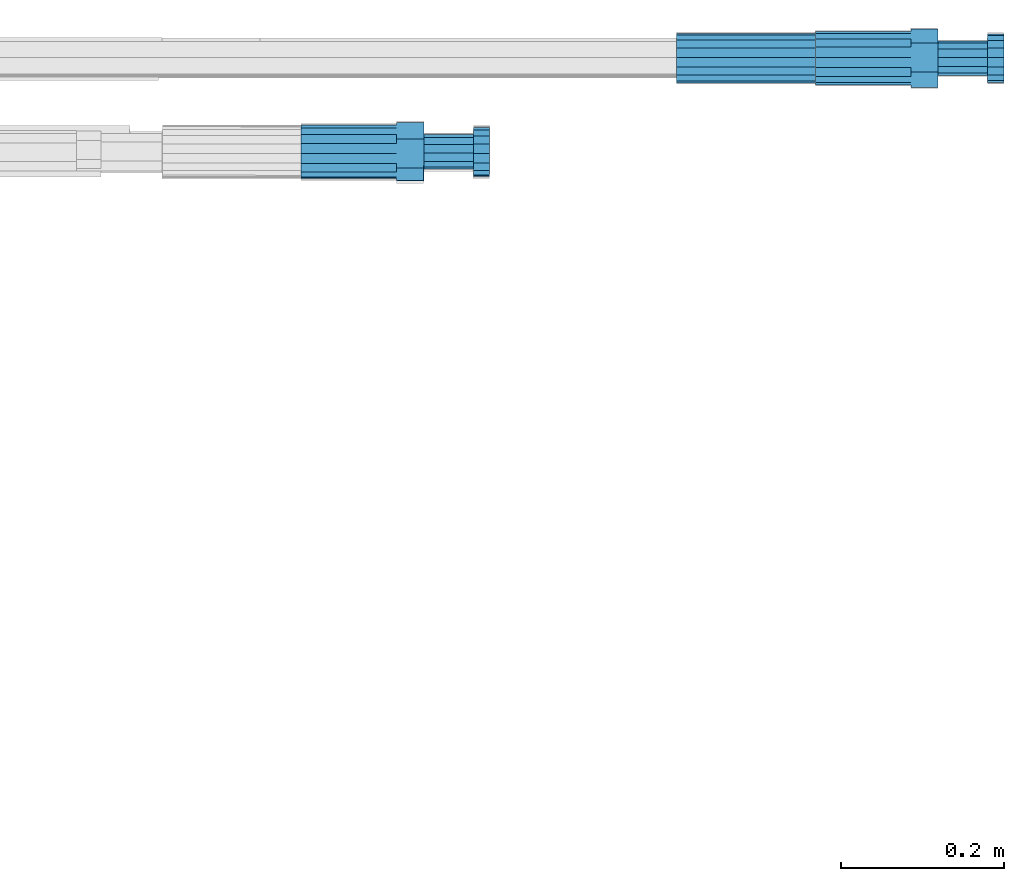
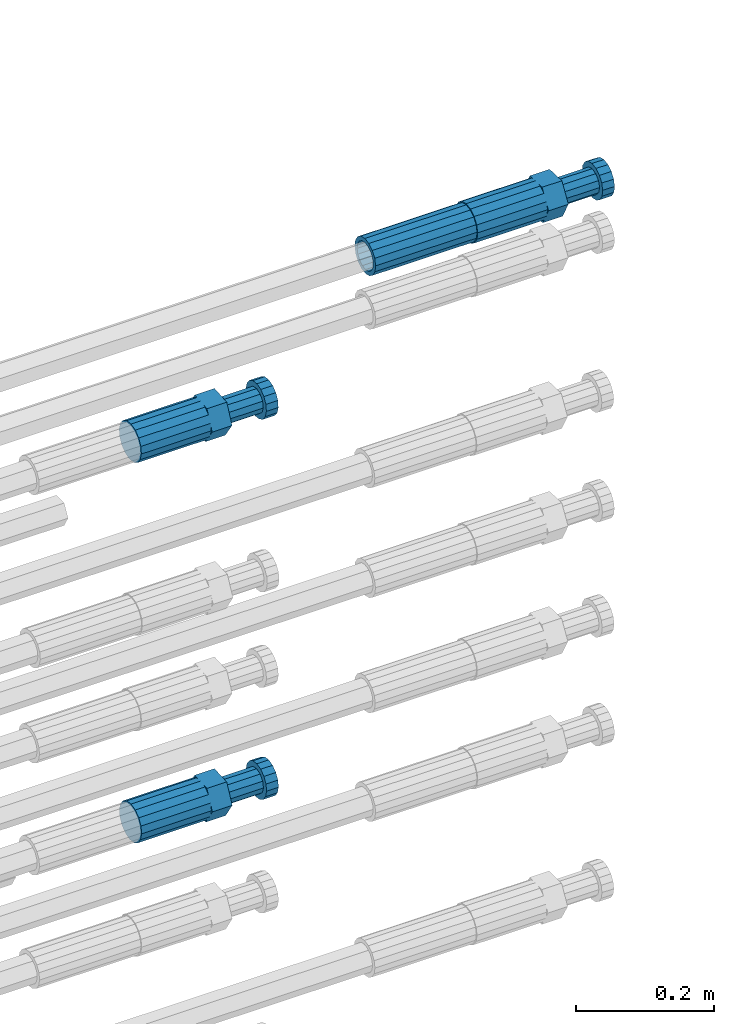
# One storey, part 111 of 177: 4 beams.
"""IFC2X3 building model written with IfcOpenShell, lengths in millimetres."""

from ifc_helpers import new_model, si_unit, frame, origin_with_axes, place, context, subcontext, project, spatial, faceted_brep, material, type_object, element, save


model = new_model("IFC2X3")

# Units and contexts
model_context_1 = context("Model", 3, precision=1e-05, world=origin_with_axes())
model_context_2 = context("Model", 3, precision=1e-05, world=origin_with_axes())
body_context = subcontext(model_context_2, "Body", "Model", "MODEL_VIEW")
ifc_project = project(units=[si_unit("LENGTHUNIT", "METRE", prefix="MILLI"), si_unit("AREAUNIT", "SQUARE_METRE"), si_unit("VOLUMEUNIT", "CUBIC_METRE"), si_unit("MASSUNIT", "GRAM", prefix="KILO"), si_unit("TIMEUNIT", "SECOND"), si_unit("PLANEANGLEUNIT", "RADIAN"), si_unit("SOLIDANGLEUNIT", "STERADIAN"), si_unit("THERMODYNAMICTEMPERATUREUNIT", "DEGREE_CELSIUS"), si_unit("LUMINOUSINTENSITYUNIT", "LUMEN")], contexts=[model_context_1])

# Site, building, storey
site_placement = place(None, origin_with_axes())
site = spatial("IfcSite", under=ifc_project, at=site_placement, CompositionType="ELEMENT")
building_placement = place(site_placement, origin_with_axes())
building = spatial("IfcBuilding", under=site, at=building_placement, Name="Undefined", CompositionType="ELEMENT")
storey_placement = place(building_placement, origin_with_axes())
storey = spatial("IfcBuildingStorey", under=building, at=storey_placement, Name="Undefined", CompositionType="ELEMENT", Elevation=0.0)

# Beams
ifc_material = material(Name="STEEL/S275")
beam_type_1 = type_object("IfcBeamType", PredefinedType="NOTDEFINED")
beam_1_placement = place(storey_placement, frame((2039349.51584447, 6206399.26006595, 20839.4518890081), z_axis=(0.0, -0.0348994960021223, -0.999390827043554), x_axis=(1.0, 0.0, 0.0)))
element("IfcBeam", 1, at=beam_1_placement, inside=storey, type_object=beam_type_1, material=ifc_material, Name="AG40N", context=body_context, shape_type="Brep", body=[
    faceted_brep([(0.0, -23.5000000001164, -9.31322574615479e-10), (0.0, -21.7111690140155, 8.99306066054851), (170.0, -21.7111690140155, 8.99306066054851), (170.0, -23.5, 0.0), (0.0, -16.6170093578839, 16.6170093575493), (170.0, -16.6170093578839, 16.6170093575493), (0.0, -8.99306066057943, 21.7111690137535), (170.0, -8.99306066057943, 21.7111690137535), (0.0, 1.16415321826935e-10, 23.5), (170.0, 0.0, 23.5), (0.0, 8.99306066057943, 21.7111690137535), (170.0, 8.99306066057943, 21.7111690137535), (0.0, 16.6170093578839, 16.6170093575493), (170.0, 16.6170093578839, 16.6170093575493), (0.0, 21.7111690140155, 8.99306066054851), (170.0, 21.7111690140155, 8.99306066054851), (0.0, 23.5000000001164, -9.31322574615479e-10), (170.0, 23.5, 0.0), (0.0, 21.7111690140155, -8.99306066054851), (170.0, 21.7111690140155, -8.99306066054851), (0.0, 16.6170093578839, -16.6170093575493), (170.0, 16.6170093578839, -16.6170093575493), (0.0, 8.99306066057943, -21.7111690137535), (170.0, 8.99306066057943, -21.7111690137535), (0.0, 1.16415321826935e-10, -23.5000000009313), (170.0, 0.0, -23.5), (0.0, -8.99306066057943, -21.7111690137535), (170.0, -8.99306066057943, -21.7111690137535), (0.0, -16.6170093578839, -16.6170093575493), (170.0, -16.6170093578839, -16.6170093575493), (0.0, -21.7111690140155, -8.99306066054851), (170.0, -21.7111690140155, -8.99306066054851), (0.0, -30.5, 0.0), (0.0, -28.1783257415937, -11.6718446873128), (170.0, -28.1783257415937, -11.6718446873128), (170.0, -30.5, 0.0), (0.0, -21.5667568261888, -21.5667568258941), (170.0, -21.5667568261888, -21.5667568258941), (0.0, -11.6718446871346, -28.1783257415518), (170.0, -11.6718446871346, -28.1783257415518), (0.0, 0.0, -30.5), (170.0, 0.0, -30.5), (0.0, 11.6718446871346, -28.1783257415518), (170.0, 11.6718446871346, -28.1783257415518), (0.0, 21.5667568261888, -21.5667568258941), (170.0, 21.5667568261888, -21.5667568258941), (0.0, 28.1783257415937, -11.6718446873128), (170.0, 28.1783257415937, -11.6718446873128), (0.0, 30.5, 0.0), (170.0, 30.5, 0.0), (0.0, 28.1783257415937, 11.6718446873128), (170.0, 28.1783257415937, 11.6718446873128), (0.0, 21.5667568261888, 21.5667568258941), (170.0, 21.5667568261888, 21.5667568258941), (0.0, 11.6718446871346, 28.1783257415518), (170.0, 11.6718446871346, 28.1783257415518), (0.0, 0.0, 30.5), (170.0, 0.0, 30.5), (0.0, -11.6718446871346, 28.1783257415518), (170.0, -11.6718446871346, 28.1783257415518), (0.0, -21.5667568261888, 21.5667568258941), (170.0, -21.5667568261888, 21.5667568258941), (0.0, -28.1783257415937, 11.6718446873128), (170.0, -28.1783257415937, 11.6718446873128)], [[[0, 1, 2, 3]], [[1, 4, 5, 2]], [[4, 6, 7, 5]], [[6, 8, 9, 7]], [[8, 10, 11, 9]], [[10, 12, 13, 11]], [[12, 14, 15, 13]], [[14, 16, 17, 15]], [[16, 18, 19, 17]], [[18, 20, 21, 19]], [[20, 22, 23, 21]], [[22, 24, 25, 23]], [[24, 26, 27, 25]], [[26, 28, 29, 27]], [[28, 30, 31, 29]], [[30, 0, 3, 31]], [[32, 33, 34, 35]], [[33, 36, 37, 34]], [[36, 38, 39, 37]], [[38, 40, 41, 39]], [[40, 42, 43, 41]], [[42, 44, 45, 43]], [[44, 46, 47, 45]], [[46, 48, 49, 47]], [[48, 50, 51, 49]], [[50, 52, 53, 51]], [[52, 54, 55, 53]], [[54, 56, 57, 55]], [[56, 58, 59, 57]], [[58, 60, 61, 59]], [[60, 62, 63, 61]], [[62, 32, 35, 63]], [[37, 39, 41, 43, 45, 47, 49, 51, 53, 55, 57, 59, 61, 63, 35, 34], [5, 7, 9, 11, 13, 15, 17, 19, 21, 23, 25, 27, 29, 31, 3, 2]], [[62, 60, 58, 56, 54, 52, 50, 48, 46, 44, 42, 40, 38, 36, 33, 32], [30, 28, 26, 24, 22, 20, 18, 16, 14, 12, 10, 8, 6, 4, 1, 0]]]),
])
beam_type_2 = type_object("IfcBeamType", Name="ROD65", PredefinedType="NOTDEFINED")
beam_2_placement = place(storey_placement, frame((2039519.51584447, 6206399.26006595, 20839.4518890082), z_axis=(0.0, -0.0348994960021223, -0.999390827043554), x_axis=(1.0, 0.0, 0.0)))
element("IfcBeam", 2, at=beam_2_placement, inside=storey, type_object=beam_type_2, material=ifc_material, Name="AGB40", ObjectType="ROD65", context=body_context, shape_type="Brep", body=[
    faceted_brep([(117.0, 8.17543110251427, 30.873805644922), (117.0, 17.8250000001863, 30.873805644922), (117.0, 22.0056958701462, 23.6326279877685), (117.0, 12.4372115517035, 30.0260848065373), (117.0, -17.8250000001863, 30.873805644922), (150.200000000186, -17.8250000001863, 30.873805644922), (150.200000000186, 17.8250000001863, 30.873805644922), (117.0, -8.17543110251427, 30.873805644922), (117.0, -12.4372115517035, 30.0260848065373), (117.0, -22.0056958701462, 23.6326279877685), (117.0, -35.6500000003725, 0.0), (150.200000000186, -35.6500000003725, 0.0), (117.0, -30.8443150008097, 8.32369058486074), (117.0, -32.5, 0.0), (117.0, -30.8443150008097, -8.32369058462791), (117.0, -17.8250000001863, -30.873805644922), (150.200000000186, -17.8250000001863, -30.873805644922), (117.0, -22.0056958701462, -23.6326279877685), (117.0, -12.4372115517035, -30.0260848065373), (117.0, -8.17543110251427, -30.873805644922), (117.0, 17.8250000001863, -30.873805644922), (150.200000000186, 17.8250000001863, -30.873805644922), (117.0, 8.17543110251427, -30.873805644922), (117.0, 22.0056958701462, -23.6326279877685), (117.0, 12.4372115517035, -30.0260848065373), (117.0, 35.6500000003725, 0.0), (150.200000000186, 35.6500000003725, 0.0), (117.0, 30.8443150008097, -8.32369058486074), (117.0, 30.8443150008097, 8.32369058462791), (117.0, 32.5, 0.0), (0.0, -22.9809703892097, 22.9809703885621), (0.0, -30.0260848058388, 12.4372115518636), (117.0, -30.0260848067701, 12.4372115519363), (117.0, -22.9809703882784, 22.9809703885112), (-2.3283064365387e-10, 22.9809703892097, -22.9809703885639), (-4.65661287307739e-10, 30.0260848077014, -12.4372115518672), (117.0, 30.0260848067701, -12.4372115519363), (117.0, 22.9809703882784, -22.9809703885112), (-2.3283064365387e-10, -30.0260848067701, -12.4372115518672), (-2.3283064365387e-10, -22.9809703892097, -22.9809703885621), (117.0, -22.9809703882784, -22.9809703885112), (117.0, -30.0260848067701, -12.4372115519363), (-2.3283064365387e-10, -12.4372115507722, 30.0260848066137), (-2.3283064365387e-10, 9.31322574615479e-10, 32.4999999999982), (-2.3283064365387e-10, 12.4372115526348, 30.0260848066137), (0.0, 22.9809703892097, 22.9809703885621), (-2.3283064365387e-10, 30.0260848077014, 12.4372115518636), (-2.3283064365387e-10, 32.5, 0.0), (-2.3283064365387e-10, 12.4372115526348, -30.0260848066173), (-2.3283064365387e-10, 9.31322574615479e-10, -32.5), (-2.3283064365387e-10, -12.4372115517035, -30.0260848066173), (-4.65661287307739e-10, -32.4999999990687, -1.81898940354586e-12), (117.0, 22.9809703882784, 22.9809703885112), (117.0, 30.0260848067701, 12.4372115519363), (117.0, 0.0, -32.5), (117.0, 0.0, 32.5), (150.200000000186, 10.5, -18.1865334794857), (150.200000000186, 0.0, -21.0), (150.200000000186, -10.5, -18.1865334794857), (150.200000000186, -18.18653347902, -10.5), (150.200000000186, -21.0, 0.0), (150.200000000186, -18.18653347902, 10.5), (150.200000000186, -10.5, 18.1865334794857), (150.200000000186, 0.0, 21.0), (150.200000000186, 10.5, 18.1865334794857), (150.200000000186, 18.18653347902, 10.5), (150.200000000186, 21.0, 0.0), (150.200000000186, 18.18653347902, -10.5), (210.980000000447, -18.18653347902, 10.5), (210.980000000447, -21.0, 0.0), (210.980000000447, -10.5, 18.1865334794857), (210.980000000447, 0.0, 21.0), (210.980000000447, 10.5, 18.1865334794857), (210.980000000447, 18.18653347902, 10.5), (210.980000000447, 21.0, 0.0), (210.980000000447, 18.18653347902, -10.5), (210.980000000447, 10.5, -18.1865334794857), (210.980000000447, 0.0, -21.0), (210.980000000447, -10.5, -18.1865334794857), (210.980000000447, -18.18653347902, -10.5), (211.001368442696, -27.7269937992096, -11.491116326768), (211.003082550167, -21.2238094303757, -21.223815418547), (231.002518367059, -21.2131944671273, -21.2132004550658), (231.000804259587, -27.7163788359612, -11.4805013632867), (211.001368440451, -11.4911085031927, -27.7269970395137), (231.000804257343, -11.4804935399443, -27.7163820760325), (210.996487071217, -0.0106065049767494, -30.0106107392348), (230.995922888109, 8.45827162265778e-06, -29.9999957757536), (210.989181586672, 11.46989420522, -27.7269970329944), (230.988617403564, 11.4805091684684, -27.7163820695132), (210.980564180623, 21.2025914648548, -21.2238154064398), (230.979999997515, 21.2132064281031, -21.2132004429586), (210.971946775022, 27.7057703435421, -11.4911163107026), (230.971382591913, 27.7163853067905, -11.4805013472214), (210.96464129175, 29.9893808094785, -0.0106149562634528), (230.964077108642, 29.9999957727268, 7.21774995326996e-09), (210.959759924415, 27.7057638689876, 11.4698863970116), (230.959195741307, 27.7163788322359, 11.4805013604928), (210.958045816944, 21.2025795001537, 21.2025854887906), (230.957481633835, 21.213194463402, 21.2132004522718), (210.95975992666, 11.4698785729706, 27.7057671097573), (230.959195743551, 11.480493536219, 27.7163820732385), (210.964641295894, -0.010623425245285, 29.9893808094785), (230.964077112785, -8.46199691295624e-06, 29.9999957729597), (210.971946780439, -11.4911241354421, 27.705767103238), (230.97138259733, -11.4805091721937, 27.7163820667192), (210.980564186488, -21.2238213950768, 21.2025854766835), (230.980000003379, -21.2132064318284, 21.2132004401647), (210.989181592089, -27.7270002737641, 11.4698863809463), (230.988617408981, -27.7163853105158, 11.4805013444275), (210.996487075361, -30.0106107397005, -0.0106149734929204), (230.995922892253, -29.9999957764521, -1.00117176771164e-08)], [[[0, 1, 2, 3]], [[4, 5, 6, 1, 0, 7]], [[4, 7, 8, 9]], [[10, 11, 5, 4, 9, 12]], [[10, 12, 13, 14]], [[15, 16, 11, 10, 14, 17]], [[15, 17, 18, 19]], [[20, 21, 16, 15, 19, 22]], [[23, 20, 22, 24]], [[25, 26, 21, 20, 23, 27]], [[28, 25, 27, 29]], [[30, 31, 32, 33]], [[34, 35, 36, 37]], [[38, 39, 40, 41]], [[31, 30, 42, 43, 44, 45, 46, 47, 35, 34, 48, 49, 50, 39, 38, 51]], [[46, 45, 52, 53]], [[29, 47, 46, 53, 28]], [[27, 36, 35, 47, 29]], [[23, 37, 36, 27]], [[24, 48, 34, 37, 23]], [[22, 54, 49, 48, 24]], [[19, 54, 22]], [[18, 50, 49, 54, 19]], [[17, 40, 39, 50, 18]], [[14, 41, 40, 17]], [[13, 51, 38, 41, 14]], [[12, 32, 31, 51, 13]], [[9, 33, 32, 12]], [[8, 42, 30, 33, 9]], [[7, 55, 43, 42, 8]], [[0, 55, 7]], [[3, 44, 43, 55, 0]], [[2, 52, 45, 44, 3]], [[28, 53, 52, 2]], [[1, 6, 26, 25, 28, 2]], [[5, 11, 16, 21, 26, 6], [56, 57, 58, 59, 60, 61, 62, 63, 64, 65, 66, 67]], [[68, 61, 60, 69]], [[70, 62, 61, 68]], [[71, 63, 62, 70]], [[72, 64, 63, 71]], [[73, 65, 64, 72]], [[74, 66, 65, 73]], [[75, 67, 66, 74]], [[76, 56, 67, 75]], [[77, 57, 56, 76]], [[78, 58, 57, 77]], [[79, 59, 58, 78]], [[69, 60, 59, 79]], [[80, 81, 82, 83]], [[81, 84, 85, 82]], [[84, 86, 87, 85]], [[86, 88, 89, 87]], [[88, 90, 91, 89]], [[90, 92, 93, 91]], [[92, 94, 95, 93]], [[94, 96, 97, 95]], [[96, 98, 99, 97]], [[98, 100, 101, 99]], [[100, 102, 103, 101]], [[102, 104, 105, 103]], [[104, 106, 107, 105]], [[106, 108, 109, 107]], [[108, 110, 111, 109]], [[82, 85, 87, 89, 91, 93, 95, 97, 99, 101, 103, 105, 107, 109, 111, 83]], [[110, 80, 83, 111]], [[108, 106, 104, 102, 100, 98, 96, 94, 92, 90, 88, 86, 84, 81, 80, 110], [75, 74, 73, 72, 71, 70, 68, 69, 79, 78, 77, 76]]]),
])
beam_3_placement = place(storey_placement, frame((2038889.5180134, 6206284.86694044, 20740.9369272737), z_axis=(0.000427088183350875, 0.0766636299891423, -0.997056921861822), x_axis=(0.999999658956594, -0.000737543998569986, 0.000371638999995608)))
element("IfcBeam", 3, at=beam_3_placement, inside=storey, type_object=beam_type_2, material=ifc_material, Name="AGB40", ObjectType="ROD65", context=body_context, shape_type="Brep", body=[
    faceted_brep([(117.0, 8.17543110251427, 30.873805644922), (117.0, 17.8250000001863, 30.873805644922), (117.0, 22.0056958701462, 23.6326279877685), (117.0, 12.4372115517035, 30.0260848065373), (117.0, -17.8250000001863, 30.873805644922), (150.200000000186, -17.8250000001863, 30.873805644922), (150.200000000186, 17.8250000001863, 30.873805644922), (117.0, -8.17543110251427, 30.873805644922), (117.0, -12.4372115517035, 30.0260848065373), (117.0, -22.0056958701462, 23.6326279877685), (117.0, -35.6500000003725, 0.0), (150.200000000186, -35.6500000003725, 0.0), (117.0, -30.8443150008097, 8.32369058486074), (117.0, -32.5, 0.0), (117.0, -30.8443150008097, -8.32369058462791), (117.0, -17.8250000001863, -30.873805644922), (150.200000000186, -17.8250000001863, -30.873805644922), (117.0, -22.0056958701462, -23.6326279877685), (117.0, -12.4372115517035, -30.0260848065373), (117.0, -8.17543110251427, -30.873805644922), (117.0, 17.8250000001863, -30.873805644922), (150.200000000186, 17.8250000001863, -30.873805644922), (117.0, 8.17543110251427, -30.873805644922), (117.0, 22.0056958701462, -23.6326279877685), (117.0, 12.4372115517035, -30.0260848065373), (117.0, 35.6500000003725, 0.0), (150.200000000186, 35.6500000003725, 0.0), (117.0, 30.8443150008097, -8.32369058486074), (117.0, 30.8443150008097, 8.32369058462791), (117.0, 32.5, 0.0), (0.0, -22.9809703892097, 22.9809703885621), (0.0, -30.0260848058388, 12.4372115518636), (117.0, -30.0260848067701, 12.4372115519363), (117.0, -22.9809703882784, 22.9809703885112), (-2.3283064365387e-10, 22.9809703892097, -22.9809703885639), (-4.65661287307739e-10, 30.0260848077014, -12.4372115518672), (117.0, 30.0260848067701, -12.4372115519363), (117.0, 22.9809703882784, -22.9809703885112), (-2.3283064365387e-10, -30.0260848067701, -12.4372115518672), (-2.3283064365387e-10, -22.9809703892097, -22.9809703885621), (117.0, -22.9809703882784, -22.9809703885112), (117.0, -30.0260848067701, -12.4372115519363), (-2.3283064365387e-10, -12.4372115507722, 30.0260848066137), (-2.3283064365387e-10, 9.31322574615479e-10, 32.4999999999982), (-2.3283064365387e-10, 12.4372115526348, 30.0260848066137), (0.0, 22.9809703892097, 22.9809703885621), (-2.3283064365387e-10, 30.0260848077014, 12.4372115518636), (-2.3283064365387e-10, 32.5, 0.0), (-2.3283064365387e-10, 12.4372115526348, -30.0260848066173), (-2.3283064365387e-10, 9.31322574615479e-10, -32.5), (-2.3283064365387e-10, -12.4372115517035, -30.0260848066173), (-4.65661287307739e-10, -32.4999999990687, -1.81898940354586e-12), (117.0, 22.9809703882784, 22.9809703885112), (117.0, 30.0260848067701, 12.4372115519363), (117.0, 0.0, -32.5), (117.0, 0.0, 32.5), (150.200000000186, 10.5, -18.1865334794857), (150.200000000186, 0.0, -21.0), (150.200000000186, -10.5, -18.1865334794857), (150.200000000186, -18.18653347902, -10.5), (150.200000000186, -21.0, 0.0), (150.200000000186, -18.18653347902, 10.5), (150.200000000186, -10.5, 18.1865334794857), (150.200000000186, 0.0, 21.0), (150.200000000186, 10.5, 18.1865334794857), (150.200000000186, 18.18653347902, 10.5), (150.200000000186, 21.0, 0.0), (150.200000000186, 18.18653347902, -10.5), (210.980000000447, -18.18653347902, 10.5), (210.980000000447, -21.0, 0.0), (210.980000000447, -10.5, 18.1865334794857), (210.980000000447, 0.0, 21.0), (210.980000000447, 10.5, 18.1865334794857), (210.980000000447, 18.18653347902, 10.5), (210.980000000447, 21.0, 0.0), (210.980000000447, 18.18653347902, -10.5), (210.980000000447, 10.5, -18.1865334794857), (210.980000000447, 0.0, -21.0), (210.980000000447, -10.5, -18.1865334794857), (210.980000000447, -18.18653347902, -10.5), (211.001368442696, -27.7269937992096, -11.491116326768), (211.003082550167, -21.2238094303757, -21.223815418547), (231.002518367059, -21.2131944671273, -21.2132004550658), (231.000804259587, -27.7163788359612, -11.4805013632867), (211.001368440451, -11.4911085031927, -27.7269970395137), (231.000804257343, -11.4804935399443, -27.7163820760325), (210.996487071217, -0.0106065049767494, -30.0106107392348), (230.995922888109, 8.45827162265778e-06, -29.9999957757536), (210.989181586672, 11.46989420522, -27.7269970329944), (230.988617403564, 11.4805091684684, -27.7163820695132), (210.980564180623, 21.2025914648548, -21.2238154064398), (230.979999997515, 21.2132064281031, -21.2132004429586), (210.971946775022, 27.7057703435421, -11.4911163107026), (230.971382591913, 27.7163853067905, -11.4805013472214), (210.96464129175, 29.9893808094785, -0.0106149562634528), (230.964077108642, 29.9999957727268, 7.21774995326996e-09), (210.959759924415, 27.7057638689876, 11.4698863970116), (230.959195741307, 27.7163788322359, 11.4805013604928), (210.958045816944, 21.2025795001537, 21.2025854887906), (230.957481633835, 21.213194463402, 21.2132004522718), (210.95975992666, 11.4698785729706, 27.7057671097573), (230.959195743551, 11.480493536219, 27.7163820732385), (210.964641295894, -0.010623425245285, 29.9893808094785), (230.964077112785, -8.46199691295624e-06, 29.9999957729597), (210.971946780439, -11.4911241354421, 27.705767103238), (230.97138259733, -11.4805091721937, 27.7163820667192), (210.980564186488, -21.2238213950768, 21.2025854766835), (230.980000003379, -21.2132064318284, 21.2132004401647), (210.989181592089, -27.7270002737641, 11.4698863809463), (230.988617408981, -27.7163853105158, 11.4805013444275), (210.996487075361, -30.0106107397005, -0.0106149734929204), (230.995922892253, -29.9999957764521, -1.00117176771164e-08)], [[[0, 1, 2, 3]], [[4, 5, 6, 1, 0, 7]], [[4, 7, 8, 9]], [[10, 11, 5, 4, 9, 12]], [[10, 12, 13, 14]], [[15, 16, 11, 10, 14, 17]], [[15, 17, 18, 19]], [[20, 21, 16, 15, 19, 22]], [[23, 20, 22, 24]], [[25, 26, 21, 20, 23, 27]], [[28, 25, 27, 29]], [[30, 31, 32, 33]], [[34, 35, 36, 37]], [[38, 39, 40, 41]], [[31, 30, 42, 43, 44, 45, 46, 47, 35, 34, 48, 49, 50, 39, 38, 51]], [[46, 45, 52, 53]], [[29, 47, 46, 53, 28]], [[27, 36, 35, 47, 29]], [[23, 37, 36, 27]], [[24, 48, 34, 37, 23]], [[22, 54, 49, 48, 24]], [[19, 54, 22]], [[18, 50, 49, 54, 19]], [[17, 40, 39, 50, 18]], [[14, 41, 40, 17]], [[13, 51, 38, 41, 14]], [[12, 32, 31, 51, 13]], [[9, 33, 32, 12]], [[8, 42, 30, 33, 9]], [[7, 55, 43, 42, 8]], [[0, 55, 7]], [[3, 44, 43, 55, 0]], [[2, 52, 45, 44, 3]], [[28, 53, 52, 2]], [[1, 6, 26, 25, 28, 2]], [[5, 11, 16, 21, 26, 6], [56, 57, 58, 59, 60, 61, 62, 63, 64, 65, 66, 67]], [[68, 61, 60, 69]], [[70, 62, 61, 68]], [[71, 63, 62, 70]], [[72, 64, 63, 71]], [[73, 65, 64, 72]], [[74, 66, 65, 73]], [[75, 67, 66, 74]], [[76, 56, 67, 75]], [[77, 57, 56, 76]], [[78, 58, 57, 77]], [[79, 59, 58, 78]], [[69, 60, 59, 79]], [[80, 81, 82, 83]], [[81, 84, 85, 82]], [[84, 86, 87, 85]], [[86, 88, 89, 87]], [[88, 90, 91, 89]], [[90, 92, 93, 91]], [[92, 94, 95, 93]], [[94, 96, 97, 95]], [[96, 98, 99, 97]], [[98, 100, 101, 99]], [[100, 102, 103, 101]], [[102, 104, 105, 103]], [[104, 106, 107, 105]], [[106, 108, 109, 107]], [[108, 110, 111, 109]], [[82, 85, 87, 89, 91, 93, 95, 97, 99, 101, 103, 105, 107, 109, 111, 83]], [[110, 80, 83, 111]], [[108, 106, 104, 102, 100, 98, 96, 94, 92, 90, 88, 86, 84, 81, 80, 110], [75, 74, 73, 72, 71, 70, 68, 69, 79, 78, 77, 76]]]),
])
beam_4_placement = place(storey_placement, frame((2038889.51584447, 6206284.25478352, 20067.1623283), z_axis=(0.0, 0.0505929410066467, -0.998719357137078), x_axis=(1.0, 0.0, 0.0)))
element("IfcBeam", 4, at=beam_4_placement, inside=storey, type_object=beam_type_2, material=ifc_material, Name="AGB40", ObjectType="ROD65", context=body_context, shape_type="Brep", body=[
    faceted_brep([(117.0, 8.17543110251427, 30.873805644922), (117.0, 17.8250000001863, 30.873805644922), (117.0, 22.0056958701462, 23.6326279877685), (117.0, 12.4372115517035, 30.0260848065373), (117.0, -17.8250000001863, 30.873805644922), (150.200000000186, -17.8250000001863, 30.873805644922), (150.200000000186, 17.8250000001863, 30.873805644922), (117.0, -8.17543110251427, 30.873805644922), (117.0, -12.4372115517035, 30.0260848065373), (117.0, -22.0056958701462, 23.6326279877685), (117.0, -35.6500000003725, 0.0), (150.200000000186, -35.6500000003725, 0.0), (117.0, -30.8443150008097, 8.32369058486074), (117.0, -32.5, 0.0), (117.0, -30.8443150008097, -8.32369058462791), (117.0, -17.8250000001863, -30.873805644922), (150.200000000186, -17.8250000001863, -30.873805644922), (117.0, -22.0056958701462, -23.6326279877685), (117.0, -12.4372115517035, -30.0260848065373), (117.0, -8.17543110251427, -30.873805644922), (117.0, 17.8250000001863, -30.873805644922), (150.200000000186, 17.8250000001863, -30.873805644922), (117.0, 8.17543110251427, -30.873805644922), (117.0, 22.0056958701462, -23.6326279877685), (117.0, 12.4372115517035, -30.0260848065373), (117.0, 35.6500000003725, 0.0), (150.200000000186, 35.6500000003725, 0.0), (117.0, 30.8443150008097, -8.32369058486074), (117.0, 30.8443150008097, 8.32369058462791), (117.0, 32.5, 0.0), (0.0, -22.9809703892097, 22.9809703885621), (0.0, -30.0260848058388, 12.4372115518636), (117.0, -30.0260848067701, 12.4372115519363), (117.0, -22.9809703882784, 22.9809703885112), (-2.3283064365387e-10, 22.9809703892097, -22.9809703885639), (-4.65661287307739e-10, 30.0260848077014, -12.4372115518672), (117.0, 30.0260848067701, -12.4372115519363), (117.0, 22.9809703882784, -22.9809703885112), (-2.3283064365387e-10, -30.0260848067701, -12.4372115518672), (-2.3283064365387e-10, -22.9809703892097, -22.9809703885621), (117.0, -22.9809703882784, -22.9809703885112), (117.0, -30.0260848067701, -12.4372115519363), (-2.3283064365387e-10, -12.4372115507722, 30.0260848066137), (-2.3283064365387e-10, 9.31322574615479e-10, 32.4999999999982), (-2.3283064365387e-10, 12.4372115526348, 30.0260848066137), (0.0, 22.9809703892097, 22.9809703885621), (-2.3283064365387e-10, 30.0260848077014, 12.4372115518636), (-2.3283064365387e-10, 32.5, 0.0), (-2.3283064365387e-10, 12.4372115526348, -30.0260848066173), (-2.3283064365387e-10, 9.31322574615479e-10, -32.5), (-2.3283064365387e-10, -12.4372115517035, -30.0260848066173), (-4.65661287307739e-10, -32.4999999990687, -1.81898940354586e-12), (117.0, 22.9809703882784, 22.9809703885112), (117.0, 30.0260848067701, 12.4372115519363), (117.0, 0.0, -32.5), (117.0, 0.0, 32.5), (150.200000000186, 10.5, -18.1865334794857), (150.200000000186, 0.0, -21.0), (150.200000000186, -10.5, -18.1865334794857), (150.200000000186, -18.18653347902, -10.5), (150.200000000186, -21.0, 0.0), (150.200000000186, -18.18653347902, 10.5), (150.200000000186, -10.5, 18.1865334794857), (150.200000000186, 0.0, 21.0), (150.200000000186, 10.5, 18.1865334794857), (150.200000000186, 18.18653347902, 10.5), (150.200000000186, 21.0, 0.0), (150.200000000186, 18.18653347902, -10.5), (210.980000000447, -18.18653347902, 10.5), (210.980000000447, -21.0, 0.0), (210.980000000447, -10.5, 18.1865334794857), (210.980000000447, 0.0, 21.0), (210.980000000447, 10.5, 18.1865334794857), (210.980000000447, 18.18653347902, 10.5), (210.980000000447, 21.0, 0.0), (210.980000000447, 18.18653347902, -10.5), (210.980000000447, 10.5, -18.1865334794857), (210.980000000447, 0.0, -21.0), (210.980000000447, -10.5, -18.1865334794857), (210.980000000447, -18.18653347902, -10.5), (211.001368442696, -27.7269937992096, -11.491116326768), (211.003082550167, -21.2238094303757, -21.223815418547), (231.002518367059, -21.2131944671273, -21.2132004550658), (231.000804259587, -27.7163788359612, -11.4805013632867), (211.001368440451, -11.4911085031927, -27.7269970395137), (231.000804257343, -11.4804935399443, -27.7163820760325), (210.996487071217, -0.0106065049767494, -30.0106107392348), (230.995922888109, 8.45827162265778e-06, -29.9999957757536), (210.989181586672, 11.46989420522, -27.7269970329944), (230.988617403564, 11.4805091684684, -27.7163820695132), (210.980564180623, 21.2025914648548, -21.2238154064398), (230.979999997515, 21.2132064281031, -21.2132004429586), (210.971946775022, 27.7057703435421, -11.4911163107026), (230.971382591913, 27.7163853067905, -11.4805013472214), (210.96464129175, 29.9893808094785, -0.0106149562634528), (230.964077108642, 29.9999957727268, 7.21774995326996e-09), (210.959759924415, 27.7057638689876, 11.4698863970116), (230.959195741307, 27.7163788322359, 11.4805013604928), (210.958045816944, 21.2025795001537, 21.2025854887906), (230.957481633835, 21.213194463402, 21.2132004522718), (210.95975992666, 11.4698785729706, 27.7057671097573), (230.959195743551, 11.480493536219, 27.7163820732385), (210.964641295894, -0.010623425245285, 29.9893808094785), (230.964077112785, -8.46199691295624e-06, 29.9999957729597), (210.971946780439, -11.4911241354421, 27.705767103238), (230.97138259733, -11.4805091721937, 27.7163820667192), (210.980564186488, -21.2238213950768, 21.2025854766835), (230.980000003379, -21.2132064318284, 21.2132004401647), (210.989181592089, -27.7270002737641, 11.4698863809463), (230.988617408981, -27.7163853105158, 11.4805013444275), (210.996487075361, -30.0106107397005, -0.0106149734929204), (230.995922892253, -29.9999957764521, -1.00117176771164e-08)], [[[0, 1, 2, 3]], [[4, 5, 6, 1, 0, 7]], [[4, 7, 8, 9]], [[10, 11, 5, 4, 9, 12]], [[10, 12, 13, 14]], [[15, 16, 11, 10, 14, 17]], [[15, 17, 18, 19]], [[20, 21, 16, 15, 19, 22]], [[23, 20, 22, 24]], [[25, 26, 21, 20, 23, 27]], [[28, 25, 27, 29]], [[30, 31, 32, 33]], [[34, 35, 36, 37]], [[38, 39, 40, 41]], [[31, 30, 42, 43, 44, 45, 46, 47, 35, 34, 48, 49, 50, 39, 38, 51]], [[46, 45, 52, 53]], [[29, 47, 46, 53, 28]], [[27, 36, 35, 47, 29]], [[23, 37, 36, 27]], [[24, 48, 34, 37, 23]], [[22, 54, 49, 48, 24]], [[19, 54, 22]], [[18, 50, 49, 54, 19]], [[17, 40, 39, 50, 18]], [[14, 41, 40, 17]], [[13, 51, 38, 41, 14]], [[12, 32, 31, 51, 13]], [[9, 33, 32, 12]], [[8, 42, 30, 33, 9]], [[7, 55, 43, 42, 8]], [[0, 55, 7]], [[3, 44, 43, 55, 0]], [[2, 52, 45, 44, 3]], [[28, 53, 52, 2]], [[1, 6, 26, 25, 28, 2]], [[5, 11, 16, 21, 26, 6], [56, 57, 58, 59, 60, 61, 62, 63, 64, 65, 66, 67]], [[68, 61, 60, 69]], [[70, 62, 61, 68]], [[71, 63, 62, 70]], [[72, 64, 63, 71]], [[73, 65, 64, 72]], [[74, 66, 65, 73]], [[75, 67, 66, 74]], [[76, 56, 67, 75]], [[77, 57, 56, 76]], [[78, 58, 57, 77]], [[79, 59, 58, 78]], [[69, 60, 59, 79]], [[80, 81, 82, 83]], [[81, 84, 85, 82]], [[84, 86, 87, 85]], [[86, 88, 89, 87]], [[88, 90, 91, 89]], [[90, 92, 93, 91]], [[92, 94, 95, 93]], [[94, 96, 97, 95]], [[96, 98, 99, 97]], [[98, 100, 101, 99]], [[100, 102, 103, 101]], [[102, 104, 105, 103]], [[104, 106, 107, 105]], [[106, 108, 109, 107]], [[108, 110, 111, 109]], [[82, 85, 87, 89, 91, 93, 95, 97, 99, 101, 103, 105, 107, 109, 111, 83]], [[110, 80, 83, 111]], [[108, 106, 104, 102, 100, 98, 96, 94, 92, 90, 88, 86, 84, 81, 80, 110], [75, 74, 73, 72, 71, 70, 68, 69, 79, 78, 77, 76]]]),
])

save(model, "model.ifc")
